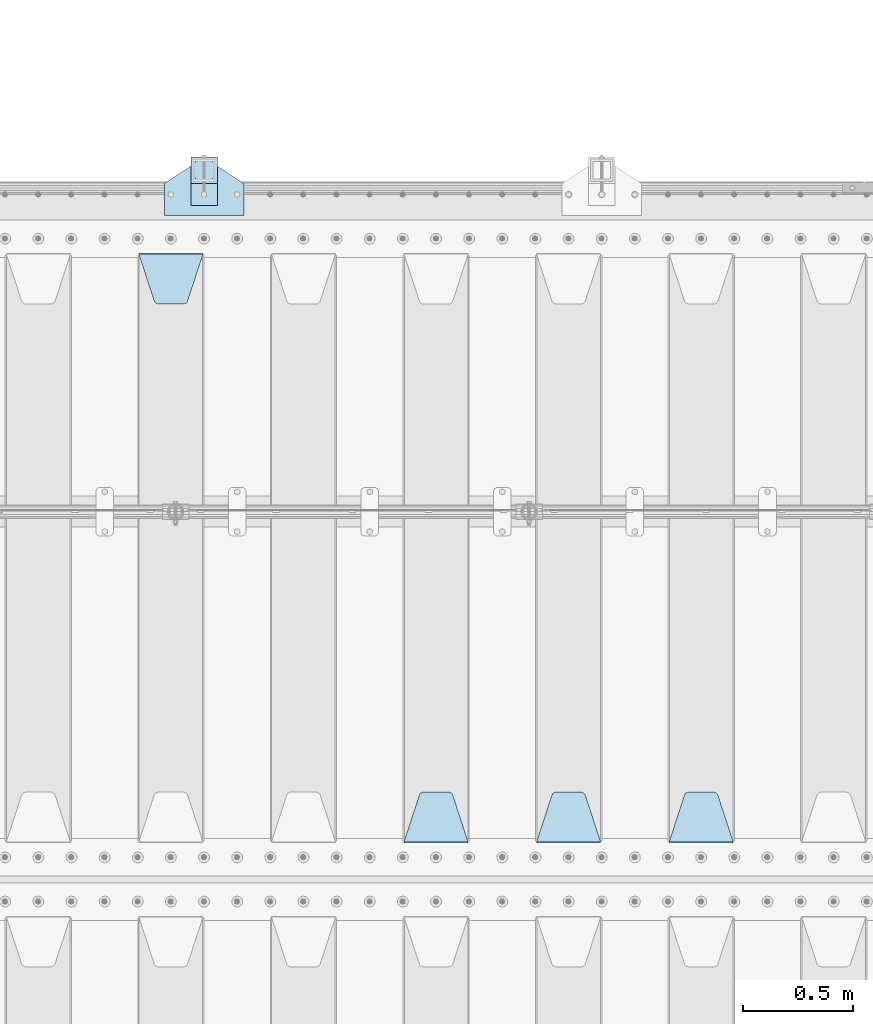
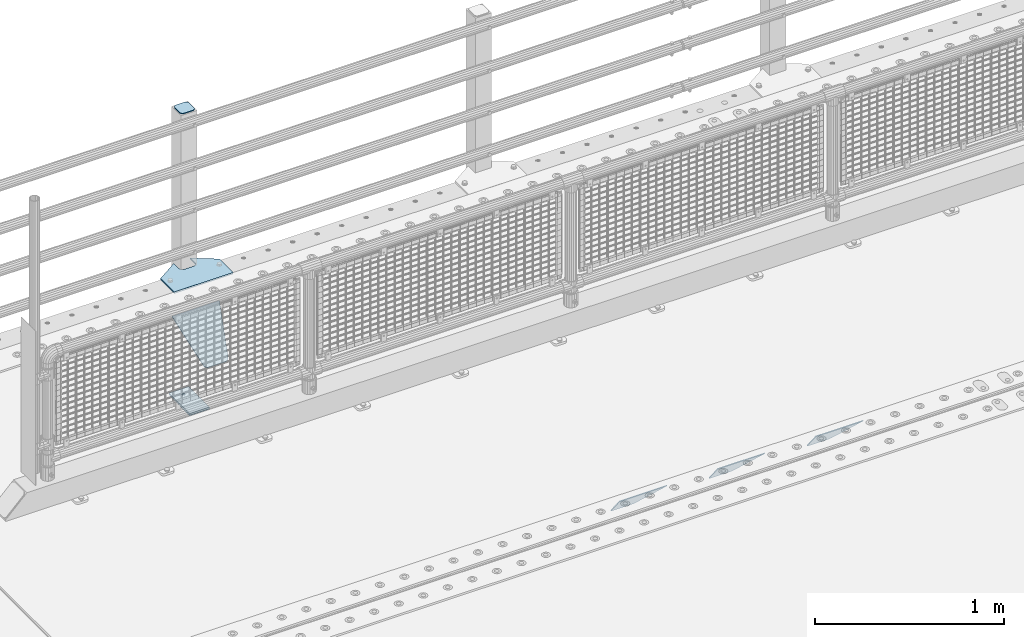
# One storey, part 172 of 208: 8 plates.
"""IFC2X3 building model written with IfcOpenShell, lengths in millimetres."""

from ifc_helpers import new_model, si_unit, frame, origin_with_axes, place, context, subcontext, project, spatial, faceted_brep, material, type_object, element, save


model = new_model("IFC2X3")

# Units and contexts
model_context = context("Model", 3, precision=1e-05, world=origin_with_axes())
body_context = subcontext(model_context, "Body", "Model", "MODEL_VIEW")
ifc_project = project(units=[si_unit("LENGTHUNIT", "METRE", prefix="MILLI"), si_unit("AREAUNIT", "SQUARE_METRE"), si_unit("VOLUMEUNIT", "CUBIC_METRE"), si_unit("MASSUNIT", "GRAM", prefix="KILO"), si_unit("TIMEUNIT", "SECOND"), si_unit("PLANEANGLEUNIT", "RADIAN"), si_unit("SOLIDANGLEUNIT", "STERADIAN"), si_unit("THERMODYNAMICTEMPERATUREUNIT", "DEGREE_CELSIUS"), si_unit("LUMINOUSINTENSITYUNIT", "LUMEN")], contexts=[model_context])

# Site, building, storey
site_placement = place(None, origin_with_axes())
site = spatial("IfcSite", under=ifc_project, at=site_placement, CompositionType="ELEMENT")
building_placement = place(site_placement, origin_with_axes())
building = spatial("IfcBuilding", under=site, at=building_placement, Name="Standard", CompositionType="ELEMENT")
storey_placement = place(building_placement, origin_with_axes())
storey = spatial("IfcBuildingStorey", under=building, at=storey_placement, Name="Undefined", CompositionType="ELEMENT", Elevation=0.0)

# Plates
ifc_material_1 = material(Name="STEEL/S355N")
plate_type_1 = type_object("IfcPlateType", PredefinedType="NOTDEFINED")
plate_1_placement = place(storey_placement, frame((-37705.0, 3168.23223304702, -1.76776695296758), z_axis=(0.0, 0.707106781186547, -0.707106781186548), x_axis=(-1.0, 0.0, 0.0)))
element("IfcPlate", 1, at=plate_1_placement, inside=storey, type_object=plate_type_1, material=ifc_material_1, context=body_context, shape_type="Brep", body=[
    faceted_brep([(0.0, -2.5, 0.0), (69.345504679477, -2.5, 300.17173142483), (69.345504679477, 2.5, 300.17173142483), (0.0, 2.5, 0.0), (70.9274061199576, -2.5, 304.897442415399), (70.9274061199576, 2.5, 304.8974424154), (73.3818627772307, -2.5, 309.234538108527), (73.3818627772307, 2.5, 309.234538108527), (76.6187032999551, -2.5, 313.023683126103), (76.6187032999551, 2.5, 313.023683126103), (80.5190132704993, -2.5, 316.125672595371), (80.5190132704993, 2.5, 316.125672595371), (84.9395038596849, -2.5, 318.426546230476), (84.9395038596849, 2.50000000000091, 318.426546230476), (89.7177759439219, -2.5, 319.841774983275), (89.7177759439219, 2.50000000000091, 319.841774983275), (94.678286292652, -2.49999999999909, 320.319366455078), (94.678286292652, 2.5, 320.319366455078), (195.321713707348, -2.49999999999909, 320.319366455078), (195.321713707348, 2.5, 320.319366455078), (200.282224056078, -2.5, 319.841774983275), (200.282224056078, 2.5, 319.841774983274), (205.060496140315, -2.5, 318.426546230475), (205.060496140315, 2.5, 318.426546230475), (209.480986729501, -2.5, 316.125672595371), (209.480986729501, 2.50000000000091, 316.125672595371), (213.381296700045, -2.5, 313.023683126102), (213.381296700045, 2.5, 313.023683126102), (216.618137222769, -2.5, 309.234538108526), (216.618137222769, 2.5, 309.234538108527), (219.072593880042, -2.5, 304.897442415399), (219.072593880042, 2.5, 304.897442415399), (220.654495320523, -2.5, 300.17173142483), (220.654495320523, 2.5, 300.17173142483), (290.0, -2.5, 0.0), (290.0, 2.5, 0.0)], [[[0, 1, 2, 3]], [[1, 4, 5, 2]], [[4, 6, 7, 5]], [[6, 8, 9, 7]], [[8, 10, 11, 9]], [[10, 12, 13, 11]], [[12, 14, 15, 13]], [[14, 16, 17, 15]], [[16, 18, 19, 17]], [[18, 20, 21, 19]], [[20, 22, 23, 21]], [[22, 24, 25, 23]], [[24, 26, 27, 25]], [[26, 28, 29, 27]], [[28, 30, 31, 29]], [[30, 32, 33, 31]], [[32, 34, 35, 33]], [[34, 0, 3, 35]], [[5, 7, 9, 11, 13, 15, 17, 19, 21, 23, 25, 27, 29, 31, 33, 35, 3, 2]], [[34, 32, 30, 28, 26, 24, 22, 20, 18, 16, 14, 12, 10, 8, 6, 4, 1, 0]]]),
])
plate_2_placement = place(storey_placement, frame((-38305.0, 3168.23223304702, -1.76776695296758), z_axis=(0.0, 0.707106781186547, -0.707106781186548), x_axis=(-1.0, 0.0, 0.0)))
element("IfcPlate", 2, at=plate_2_placement, inside=storey, type_object=plate_type_1, material=ifc_material_1, context=body_context, shape_type="Brep", body=[
    faceted_brep([(0.0, -2.5, 0.0), (69.345504679477, -2.5, 300.17173142483), (69.345504679477, 2.5, 300.17173142483), (0.0, 2.5, 0.0), (70.9274061199576, -2.5, 304.897442415399), (70.9274061199576, 2.5, 304.8974424154), (73.3818627772307, -2.5, 309.234538108527), (73.3818627772307, 2.5, 309.234538108527), (76.6187032999551, -2.5, 313.023683126103), (76.6187032999551, 2.5, 313.023683126103), (80.5190132704993, -2.5, 316.125672595371), (80.5190132704993, 2.5, 316.125672595371), (84.9395038596849, -2.5, 318.426546230476), (84.9395038596849, 2.50000000000091, 318.426546230476), (89.7177759439219, -2.5, 319.841774983275), (89.7177759439219, 2.50000000000091, 319.841774983275), (94.678286292652, -2.49999999999909, 320.319366455078), (94.678286292652, 2.5, 320.319366455078), (195.321713707348, -2.49999999999909, 320.319366455078), (195.321713707348, 2.5, 320.319366455078), (200.282224056078, -2.5, 319.841774983275), (200.282224056078, 2.5, 319.841774983274), (205.060496140315, -2.5, 318.426546230475), (205.060496140315, 2.5, 318.426546230475), (209.480986729501, -2.5, 316.125672595371), (209.480986729501, 2.50000000000091, 316.125672595371), (213.381296700045, -2.5, 313.023683126102), (213.381296700045, 2.5, 313.023683126102), (216.618137222769, -2.5, 309.234538108526), (216.618137222769, 2.5, 309.234538108527), (219.072593880042, -2.5, 304.897442415399), (219.072593880042, 2.5, 304.897442415399), (220.654495320523, -2.5, 300.17173142483), (220.654495320523, 2.5, 300.17173142483), (290.0, -2.5, 0.0), (290.0, 2.5, 0.0)], [[[0, 1, 2, 3]], [[1, 4, 5, 2]], [[4, 6, 7, 5]], [[6, 8, 9, 7]], [[8, 10, 11, 9]], [[10, 12, 13, 11]], [[12, 14, 15, 13]], [[14, 16, 17, 15]], [[16, 18, 19, 17]], [[18, 20, 21, 19]], [[20, 22, 23, 21]], [[22, 24, 25, 23]], [[24, 26, 27, 25]], [[26, 28, 29, 27]], [[28, 30, 31, 29]], [[30, 32, 33, 31]], [[32, 34, 35, 33]], [[34, 0, 3, 35]], [[5, 7, 9, 11, 13, 15, 17, 19, 21, 23, 25, 27, 29, 31, 33, 35, 3, 2]], [[34, 32, 30, 28, 26, 24, 22, 20, 18, 16, 14, 12, 10, 8, 6, 4, 1, 0]]]),
])
plate_3_placement = place(storey_placement, frame((-38905.0, 3168.23223304702, -1.76776695296758), z_axis=(0.0, 0.707106781186547, -0.707106781186548), x_axis=(-1.0, 0.0, 0.0)))
element("IfcPlate", 3, at=plate_3_placement, inside=storey, type_object=plate_type_1, material=ifc_material_1, context=body_context, shape_type="Brep", body=[
    faceted_brep([(0.0, -2.5, 0.0), (69.345504679477, -2.5, 300.17173142483), (69.345504679477, 2.5, 300.17173142483), (0.0, 2.5, 0.0), (70.9274061199576, -2.5, 304.897442415399), (70.9274061199576, 2.5, 304.8974424154), (73.3818627772307, -2.5, 309.234538108527), (73.3818627772307, 2.5, 309.234538108527), (76.6187032999551, -2.5, 313.023683126103), (76.6187032999551, 2.5, 313.023683126103), (80.5190132704993, -2.5, 316.125672595371), (80.5190132704993, 2.5, 316.125672595371), (84.9395038596849, -2.5, 318.426546230476), (84.9395038596849, 2.50000000000091, 318.426546230476), (89.7177759439219, -2.5, 319.841774983275), (89.7177759439219, 2.50000000000091, 319.841774983275), (94.678286292652, -2.49999999999909, 320.319366455078), (94.678286292652, 2.5, 320.319366455078), (195.321713707348, -2.49999999999909, 320.319366455078), (195.321713707348, 2.5, 320.319366455078), (200.282224056078, -2.5, 319.841774983275), (200.282224056078, 2.5, 319.841774983274), (205.060496140315, -2.5, 318.426546230475), (205.060496140315, 2.5, 318.426546230475), (209.480986729501, -2.5, 316.125672595371), (209.480986729501, 2.50000000000091, 316.125672595371), (213.381296700045, -2.5, 313.023683126102), (213.381296700045, 2.5, 313.023683126102), (216.618137222769, -2.5, 309.234538108526), (216.618137222769, 2.5, 309.234538108527), (219.072593880042, -2.5, 304.897442415399), (219.072593880042, 2.5, 304.897442415399), (220.654495320523, -2.5, 300.17173142483), (220.654495320523, 2.5, 300.17173142483), (290.0, -2.5, 0.0), (290.0, 2.5, 0.0)], [[[0, 1, 2, 3]], [[1, 4, 5, 2]], [[4, 6, 7, 5]], [[6, 8, 9, 7]], [[8, 10, 11, 9]], [[10, 12, 13, 11]], [[12, 14, 15, 13]], [[14, 16, 17, 15]], [[16, 18, 19, 17]], [[18, 20, 21, 19]], [[20, 22, 23, 21]], [[22, 24, 25, 23]], [[24, 26, 27, 25]], [[26, 28, 29, 27]], [[28, 30, 31, 29]], [[30, 32, 33, 31]], [[32, 34, 35, 33]], [[34, 0, 3, 35]], [[5, 7, 9, 11, 13, 15, 17, 19, 21, 23, 25, 27, 29, 31, 33, 35, 3, 2]], [[34, 32, 30, 28, 26, 24, 22, 20, 18, 16, 14, 12, 10, 8, 6, 4, 1, 0]]]),
])
plate_4_placement = place(storey_placement, frame((-40395.0, 5831.76776695596, -1.76776695296758), z_axis=(0.0, -0.707106781186548, -0.707106781186547), x_axis=(1.0, 0.0, 0.0)))
element("IfcPlate", 4, at=plate_4_placement, inside=storey, type_object=plate_type_1, material=ifc_material_1, context=body_context, shape_type="Brep", body=[
    faceted_brep([(0.0, -2.5, 0.0), (69.345504679477, -2.5, 300.17173142483), (69.345504679477, 2.5, 300.17173142483), (0.0, 2.5, 0.0), (70.9274061199576, -2.5, 304.897442415399), (70.9274061199576, 2.5, 304.8974424154), (73.3818627772307, -2.5, 309.234538108527), (73.3818627772307, 2.5, 309.234538108527), (76.6187032999551, -2.5, 313.023683126103), (76.6187032999551, 2.5, 313.023683126103), (80.5190132704993, -2.5, 316.125672595371), (80.5190132704993, 2.5, 316.125672595371), (84.9395038596849, -2.5, 318.426546230476), (84.9395038596849, 2.50000000000091, 318.426546230476), (89.7177759439219, -2.5, 319.841774983275), (89.7177759439219, 2.50000000000091, 319.841774983275), (94.678286292652, -2.49999999999909, 320.319366455078), (94.678286292652, 2.5, 320.319366455078), (195.321713707348, -2.49999999999909, 320.319366455078), (195.321713707348, 2.5, 320.319366455078), (200.282224056078, -2.5, 319.841774983275), (200.282224056078, 2.5, 319.841774983274), (205.060496140315, -2.5, 318.426546230475), (205.060496140315, 2.5, 318.426546230475), (209.480986729501, -2.5, 316.125672595371), (209.480986729501, 2.50000000000091, 316.125672595371), (213.381296700045, -2.5, 313.023683126102), (213.381296700045, 2.5, 313.023683126102), (216.618137222769, -2.5, 309.234538108526), (216.618137222769, 2.5, 309.234538108527), (219.072593880042, -2.5, 304.897442415399), (219.072593880042, 2.5, 304.897442415399), (220.654495320523, -2.5, 300.17173142483), (220.654495320523, 2.5, 300.17173142483), (290.0, -2.5, 0.0), (290.0, 2.5, 0.0)], [[[0, 1, 2, 3]], [[1, 4, 5, 2]], [[4, 6, 7, 5]], [[6, 8, 9, 7]], [[8, 10, 11, 9]], [[10, 12, 13, 11]], [[12, 14, 15, 13]], [[14, 16, 17, 15]], [[16, 18, 19, 17]], [[18, 20, 21, 19]], [[20, 22, 23, 21]], [[22, 24, 25, 23]], [[24, 26, 27, 25]], [[26, 28, 29, 27]], [[28, 30, 31, 29]], [[30, 32, 33, 31]], [[32, 34, 35, 33]], [[34, 0, 3, 35]], [[5, 7, 9, 11, 13, 15, 17, 19, 21, 23, 25, 27, 29, 31, 33, 35, 3, 2]], [[34, 32, 30, 28, 26, 24, 22, 20, 18, 16, 14, 12, 10, 8, 6, 4, 1, 0]]]),
])
ifc_material_2 = material(Name="STEEL/S355J2")
plate_type_2 = type_object("IfcPlateType", PredefinedType="NOTDEFINED")
plate_5_placement = place(storey_placement, frame((-40280.0, 6005.0, 5.00000000004911), z_axis=(0.0, 1.0, 0.0), x_axis=(1.0, 0.0, 0.0)))
element("IfcPlate", 5, at=plate_5_placement, inside=storey, type_object=plate_type_2, material=ifc_material_2, context=body_context, shape_type="Brep", body=[
    faceted_brep([(0.0, -5.0, 0.0), (2.31396552408114e-06, -5.0, 145.0), (2.31396552408114e-06, 5.0, 145.0), (0.0, 5.0, 0.0), (130.0, -5.0, 230.0), (130.0, 5.0, 230.0), (130.0, -5.0, 180.0), (130.0, 5.0, 180.0), (130.48036798992, -5.0, 175.122741949597), (130.48036798992, 5.0, 175.122741949597), (131.903011687216, -5.0, 170.432914190873), (131.903011687216, 5.0, 170.432914190873), (134.213259692435, -5.0, 166.11074417451), (134.213259692435, 5.0, 166.11074417451), (137.322330470335, -5.0, 162.322330470336), (137.322330470335, 5.0, 162.322330470336), (141.110744174512, -5.0, 159.213259692437), (141.110744174512, 5.0, 159.213259692437), (145.432914190871, -5.0, 156.903011687218), (145.432914190871, 5.0, 156.903011687218), (150.122741949595, -5.0, 155.48036798992), (150.122741949595, 5.0, 155.48036798992), (155.0, -5.0, 155.0), (155.0, 5.0, 155.0), (205.0, -5.0, 155.0), (205.0, 5.0, 155.0), (209.877258050405, -5.0, 155.48036798992), (209.877258050405, 5.0, 155.48036798992), (214.567085809129, -5.0, 156.903011687218), (214.567085809129, 5.0, 156.903011687218), (218.889255825488, -5.0, 159.213259692437), (218.889255825488, 5.0, 159.213259692437), (222.677669529665, -5.0, 162.322330470336), (222.677669529665, 5.0, 162.322330470336), (225.786740307565, -5.0, 166.11074417451), (225.786740307565, 5.0, 166.11074417451), (228.096988312784, -5.0, 170.432914190873), (228.096988312784, 5.0, 170.432914190873), (229.51963201008, -5.0, 175.122741949597), (229.51963201008, 5.0, 175.122741949597), (230.0, -5.0, 180.0), (230.0, 5.0, 180.0), (230.0, -5.0, 230.0), (230.0, 5.0, 230.0), (360.0, -5.0, 145.0), (360.0, 5.0, 145.0), (360.0, -5.0, -7.27595761418343e-12), (360.0, 5.0, -7.27595761418343e-12)], [[[0, 1, 2, 3]], [[1, 4, 5, 2]], [[4, 6, 7, 5]], [[6, 8, 9, 7]], [[8, 10, 11, 9]], [[10, 12, 13, 11]], [[12, 14, 15, 13]], [[14, 16, 17, 15]], [[16, 18, 19, 17]], [[18, 20, 21, 19]], [[20, 22, 23, 21]], [[22, 24, 25, 23]], [[24, 26, 27, 25]], [[26, 28, 29, 27]], [[28, 30, 31, 29]], [[30, 32, 33, 31]], [[32, 34, 35, 33]], [[34, 36, 37, 35]], [[36, 38, 39, 37]], [[38, 40, 41, 39]], [[40, 42, 43, 41]], [[42, 44, 45, 43]], [[44, 46, 47, 45]], [[46, 0, 3, 47]], [[5, 7, 9, 11, 13, 15, 17, 19, 21, 23, 25, 27, 29, 31, 33, 35, 37, 39, 41, 43, 45, 47, 3, 2]], [[46, 44, 42, 40, 38, 36, 34, 32, 30, 28, 26, 24, 22, 20, 18, 16, 14, 12, 10, 8, 6, 4, 1, 0]]]),
])
plate_type_3 = type_object("IfcPlateType", PredefinedType="NOTDEFINED")
plate_6_placement = place(storey_placement, frame((-40159.9999999999, 6050.00000000021, -850.000000000002), z_axis=(0.0, 1.0, 0.0), x_axis=(1.0, 0.0, 0.0)))
element("IfcPlate", 6, at=plate_6_placement, inside=storey, type_object=plate_type_3, material=ifc_material_2, context=body_context, shape_type="Brep", body=[
    faceted_brep([(66.3639610305399, -5.0, 163.636038969112), (66.3639610305399, 5.0, 163.636038969112), (59.9999999998618, 5.0, 160.999999999791), (59.9999999998618, -5.0, 160.999999999791), (53.6360389691836, 5.0, 163.636038969112), (53.6360389691836, -5.0, 163.636038969112), (50.9999999998618, 5.0, 169.999999999791), (50.9999999998618, -5.0, 169.999999999791), (53.6360389691836, 5.0, 176.36396103047), (53.6360389691836, -5.0, 176.36396103047), (59.9999999998618, 5.0, 178.999999999791), (59.9999999998618, -5.0, 178.999999999791), (66.3639610305399, 5.0, 176.36396103047), (66.3639610305399, -5.0, 176.36396103047), (68.9999999998618, 5.0, 169.999999999791), (68.9999999998618, -5.0, 169.999999999791), (120.0, -5.0, 0.0), (120.0, -5.0, 220.0), (0.0, -5.0, 220.0), (0.0, -5.0, 0.0), (0.0, 5.0, 0.0), (120.0, 5.0, 0.0), (120.0, 5.0, 220.0), (0.0, 5.0, 220.0)], [[[0, 1, 2, 3]], [[3, 2, 4, 5]], [[5, 4, 6, 7]], [[7, 6, 8, 9]], [[9, 8, 10, 11]], [[11, 10, 12, 13]], [[13, 12, 14, 15]], [[15, 14, 1, 0]], [[16, 17, 18, 19], [3, 5, 7, 9, 11, 13, 15, 0]], [[16, 19, 20, 21]], [[17, 16, 21, 22]], [[18, 17, 22, 23]], [[19, 18, 23, 20]], [[22, 21, 20, 23], [10, 8, 6, 4, 2, 1, 14, 12]]]),
])
plate_type_4 = type_object("IfcPlateType", PredefinedType="NOTDEFINED")
plate_7_placement = place(storey_placement, frame((-40055.9999999999, 6166.00000000021, 1012.50000000001), z_axis=(0.0, 1.0, 0.0), x_axis=(-1.0, 0.0, 0.0)))
element("IfcPlate", 7, at=plate_7_placement, inside=storey, type_object=plate_type_4, material=ifc_material_2, context=body_context, shape_type="Brep", body=[
    faceted_brep([(0.0, -2.5, 19.0), (0.0, -2.5, 69.0), (0.0, 2.5, 69.0), (0.0, 2.5, 19.0), (0.476369668544066, -2.5, 73.2278977451697), (0.476369668544066, 2.5, 73.2278977451697), (1.88159150985302, -2.5, 77.2437910432336), (1.88159150985302, 2.5, 77.2437910432336), (4.14520183310742, -2.5, 80.8463062353158), (4.14520183310742, 2.5, 80.8463062353158), (7.15369376468516, -2.5, 83.8547981668926), (7.15369376468516, 2.5, 83.8547981668926), (10.7562089567655, -2.5, 86.1184084901461), (10.7562089567655, 2.5, 86.1184084901461), (14.7721022548285, -2.5, 87.523630331455), (14.7721022548285, 2.5, 87.523630331455), (19.0, -2.5, 88.0), (19.0, 2.5, 88.0), (69.0, -2.5, 88.0), (69.0, 2.5, 88.0), (73.2278977451715, -2.5, 87.523630331455), (73.2278977451715, 2.5, 87.523630331455), (77.2437910432345, -2.5, 86.1184084901461), (77.2437910432345, 2.5, 86.1184084901461), (80.8463062353148, -2.5, 83.8547981668926), (80.8463062353148, 2.5, 83.8547981668926), (83.8547981668926, -2.5, 80.8463062353158), (83.8547981668926, 2.5, 80.8463062353158), (86.118408490147, -2.5, 77.2437910432336), (86.118408490147, 2.5, 77.2437910432336), (87.5236303314559, -2.5, 73.2278977451697), (87.5236303314559, 2.5, 73.2278977451697), (88.0, -2.5, 69.0), (88.0, 2.5, 69.0), (88.0, -2.5, 19.0), (88.0, 2.5, 19.0), (87.5236303314559, -2.5, 14.7721022548303), (87.5236303314559, 2.5, 14.7721022548303), (86.118408490147, -2.5, 10.7562089567664), (86.118408490147, 2.5, 10.7562089567664), (83.8547981668926, -2.5, 7.15369376468425), (83.8547981668926, 2.5, 7.15369376468425), (80.8463062353148, -2.5, 4.14520183310742), (80.8463062353148, 2.5, 4.14520183310742), (77.2437910432345, -2.5, 1.88159150985393), (77.2437910432345, 2.5, 1.88159150985393), (73.2278977451715, -2.5, 0.476369668544976), (73.2278977451715, 2.5, 0.476369668544976), (69.0, -2.5, 0.0), (69.0, 2.5, 0.0), (19.0, -2.5, 0.0), (19.0, 2.5, 0.0), (14.7721022548285, -2.5, 0.476369668544976), (14.7721022548285, 2.5, 0.476369668544976), (10.7562089567655, -2.5, 1.88159150985393), (10.7562089567655, 2.5, 1.88159150985393), (7.15369376468516, -2.5, 4.14520183310742), (7.15369376468516, 2.5, 4.14520183310742), (4.14520183310742, -2.5, 7.15369376468425), (4.14520183310742, 2.5, 7.15369376468425), (1.88159150985302, -2.5, 10.7562089567664), (1.88159150985302, 2.5, 10.7562089567664), (0.476369668544066, -2.5, 14.7721022548303), (0.476369668544066, 2.5, 14.7721022548303)], [[[0, 1, 2, 3]], [[1, 4, 5, 2]], [[4, 6, 7, 5]], [[6, 8, 9, 7]], [[8, 10, 11, 9]], [[10, 12, 13, 11]], [[12, 14, 15, 13]], [[14, 16, 17, 15]], [[16, 18, 19, 17]], [[18, 20, 21, 19]], [[20, 22, 23, 21]], [[22, 24, 25, 23]], [[24, 26, 27, 25]], [[26, 28, 29, 27]], [[28, 30, 31, 29]], [[30, 32, 33, 31]], [[32, 34, 35, 33]], [[34, 36, 37, 35]], [[36, 38, 39, 37]], [[38, 40, 41, 39]], [[40, 42, 43, 41]], [[42, 44, 45, 43]], [[44, 46, 47, 45]], [[46, 48, 49, 47]], [[48, 50, 51, 49]], [[50, 52, 53, 51]], [[52, 54, 55, 53]], [[54, 56, 57, 55]], [[56, 58, 59, 57]], [[58, 60, 61, 59]], [[60, 62, 63, 61]], [[62, 0, 3, 63]], [[5, 7, 9, 11, 13, 15, 17, 19, 21, 23, 25, 27, 29, 31, 33, 35, 37, 39, 41, 43, 45, 47, 49, 51, 53, 55, 57, 59, 61, 63, 3, 2]], [[62, 60, 58, 56, 54, 52, 50, 48, 46, 44, 42, 40, 38, 36, 34, 32, 30, 28, 26, 24, 22, 20, 18, 16, 14, 12, 10, 8, 6, 4, 1, 0]]]),
])
plate_type_5 = type_object("IfcPlateType", PredefinedType="NOTDEFINED")
plate_8_placement = place(storey_placement, frame((-40159.9999999999, 6050.00000000021, -857.500000000002), z_axis=(0.0, 1.0, 0.0), x_axis=(1.0, 0.0, 0.0)))
element("IfcPlate", 8, at=plate_8_placement, inside=storey, type_object=plate_type_5, material=ifc_material_2, context=body_context, shape_type="Brep", body=[
    faceted_brep([(0.0, -2.5, 0.0), (0.0, -2.5, 100.0), (0.0, 2.5, 100.0), (0.0, 2.5, 0.0), (120.0, -2.5, 100.0), (120.0, 2.5, 100.0), (120.0, -2.5, 0.0), (120.0, 2.5, 0.0)], [[[0, 1, 2, 3]], [[1, 4, 5, 2]], [[4, 6, 7, 5]], [[6, 0, 3, 7]], [[5, 7, 3, 2]], [[6, 4, 1, 0]]]),
])

save(model, "model.ifc")
